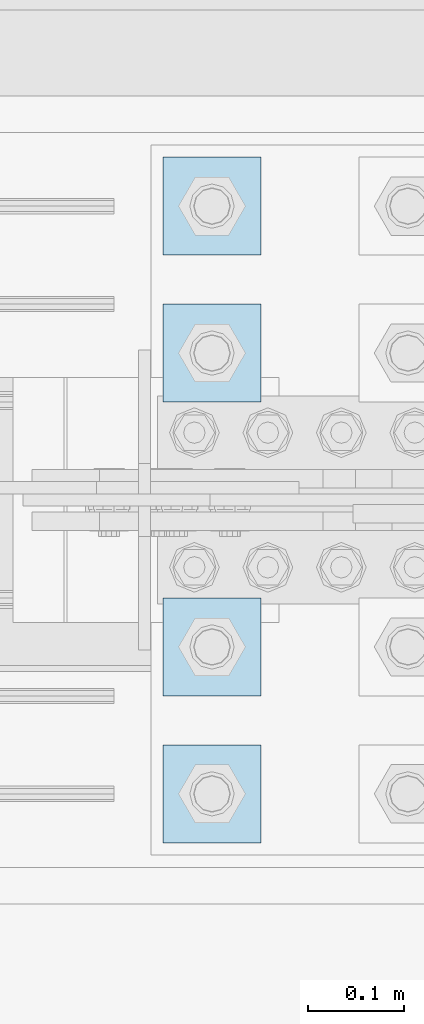
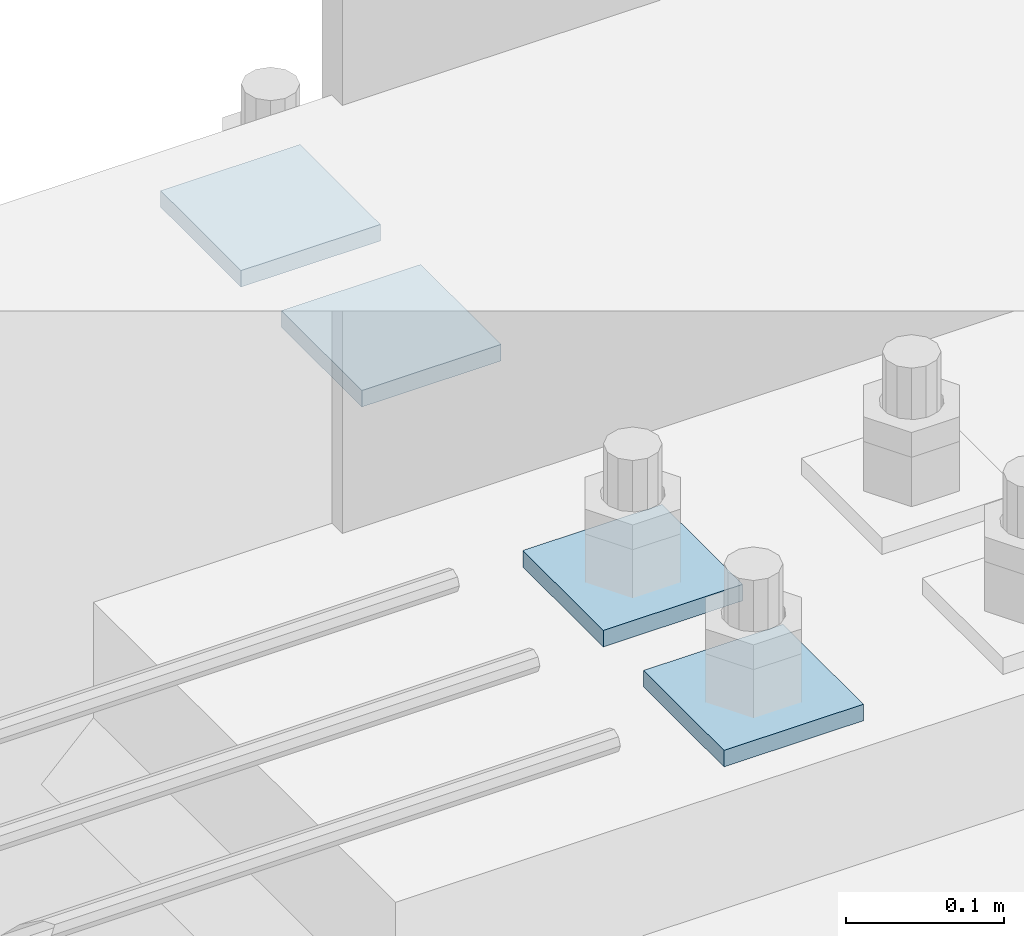
# One storey, part 3474 of 3843: 4 plates, 1 element without a shape of its own.
"""IFC2X3 building model written with IfcOpenShell, lengths in millimetres."""

from ifc_helpers import new_model, si_unit, frame, origin_with_axes, place, context, subcontext, project, spatial, faceted_brep, material, type_object, element, aggregate, save


model = new_model("IFC2X3")

# Units and contexts
model_context = context("Model", 3, precision=1e-05, world=origin_with_axes())
body_context = subcontext(model_context, "Body", "Model", "MODEL_VIEW")
ifc_project = project(units=[si_unit("LENGTHUNIT", "METRE", prefix="MILLI"), si_unit("AREAUNIT", "SQUARE_METRE"), si_unit("VOLUMEUNIT", "CUBIC_METRE"), si_unit("MASSUNIT", "GRAM", prefix="KILO"), si_unit("TIMEUNIT", "SECOND"), si_unit("PLANEANGLEUNIT", "RADIAN"), si_unit("SOLIDANGLEUNIT", "STERADIAN"), si_unit("THERMODYNAMICTEMPERATUREUNIT", "DEGREE_CELSIUS"), si_unit("LUMINOUSINTENSITYUNIT", "LUMEN")], contexts=[model_context])

# Site, building, storey
site_placement = place(None, origin_with_axes())
site = spatial("IfcSite", under=ifc_project, at=site_placement, CompositionType="ELEMENT")
building_placement = place(site_placement, origin_with_axes())
building = spatial("IfcBuilding", under=site, at=building_placement, Name="Undefined", CompositionType="ELEMENT")
storey_placement = place(building_placement, origin_with_axes())
storey = spatial("IfcBuildingStorey", under=building, at=storey_placement, Name="Undefined", CompositionType="ELEMENT", Elevation=0.0)

# Assembly, plates
assembly_placement = place(storey_placement, origin_with_axes())
assembly = element("IfcElementAssembly", 1, at=assembly_placement, inside=storey, Name="TEMPLATE", AssemblyPlace="NOTDEFINED", PredefinedType="RIGID_FRAME")
ifc_material = material(Name="STEEL/A572-50")
plate_type = type_object("IfcPlateType", PredefinedType="NOTDEFINED")
plate_1_placement = place(assembly_placement, frame((55473.6, 91960.7, 30156.15), z_axis=(-1.0, 0.0, 0.0), x_axis=(0.0, -1.0, 0.0)))
plate_1 = element("IfcPlate", 2, at=plate_1_placement, type_object=plate_type, material=ifc_material, Name="Washer Plate", context=body_context, shape_type="Brep", body=[
    faceted_brep([(0.0, -6.3499999046162, 0.0), (-1.67347025126219e-10, -6.35000000000582, 101.600000000151), (-1.67347025126219e-10, 6.35000000000582, 101.600000000151), (7.27595761418343e-12, 6.3499999046162, 0.0), (101.599998474121, -6.34999999999854, 101.599998474121), (101.599998474121, 6.34999999999854, 101.599998474121), (101.6, -6.34999999999854, 0.0), (101.6, 6.34999999999854, 0.0)], [[[0, 1, 2, 3]], [[1, 4, 5, 2]], [[4, 6, 7, 5]], [[6, 0, 3, 7]], [[5, 7, 3, 2]], [[6, 4, 1, 0]]]),
])
plate_2_placement = place(assembly_placement, frame((55473.6, 92113.1, 30156.15), z_axis=(-1.0, 0.0, 0.0), x_axis=(0.0, -1.0, 0.0)))
plate_2 = element("IfcPlate", 3, at=plate_2_placement, type_object=plate_type, material=ifc_material, Name="Washer Plate", context=body_context, shape_type="Brep", body=[
    faceted_brep([(0.0, -6.3499999046162, 0.0), (-1.67347025126219e-10, -6.35000000000582, 101.600000000151), (-1.67347025126219e-10, 6.35000000000582, 101.600000000151), (7.27595761418343e-12, 6.3499999046162, 0.0), (101.599998474121, -6.34999999999854, 101.599998474121), (101.599998474121, 6.34999999999854, 101.599998474121), (101.6, -6.34999999999854, 0.0), (101.6, 6.34999999999854, 0.0)], [[[0, 1, 2, 3]], [[1, 4, 5, 2]], [[4, 6, 7, 5]], [[6, 0, 3, 7]], [[5, 7, 3, 2]], [[6, 4, 1, 0]]]),
])
plate_3_placement = place(assembly_placement, frame((55473.6, 92417.9, 30156.15), z_axis=(-1.0, 0.0, 0.0), x_axis=(0.0, -1.0, 0.0)))
plate_3 = element("IfcPlate", 4, at=plate_3_placement, type_object=plate_type, material=ifc_material, Name="Washer Plate", context=body_context, shape_type="Brep", body=[
    faceted_brep([(0.0, -6.3499999046162, 0.0), (-1.67347025126219e-10, -6.35000000000582, 101.600000000151), (-1.67347025126219e-10, 6.35000000000582, 101.600000000151), (7.27595761418343e-12, 6.3499999046162, 0.0), (101.599998474121, -6.34999999999854, 101.599998474121), (101.599998474121, 6.34999999999854, 101.599998474121), (101.6, -6.34999999999854, 0.0), (101.6, 6.34999999999854, 0.0)], [[[0, 1, 2, 3]], [[1, 4, 5, 2]], [[4, 6, 7, 5]], [[6, 0, 3, 7]], [[5, 7, 3, 2]], [[6, 4, 1, 0]]]),
])
plate_4_placement = place(assembly_placement, frame((55473.6, 92570.3, 30156.15), z_axis=(-1.0, 0.0, 0.0), x_axis=(0.0, -1.0, 0.0)))
plate_4 = element("IfcPlate", 5, at=plate_4_placement, type_object=plate_type, material=ifc_material, Name="Washer Plate", context=body_context, shape_type="Brep", body=[
    faceted_brep([(0.0, -6.3499999046162, 0.0), (-1.67347025126219e-10, -6.35000000000582, 101.600000000151), (-1.67347025126219e-10, 6.35000000000582, 101.600000000151), (7.27595761418343e-12, 6.3499999046162, 0.0), (101.599998474121, -6.34999999999854, 101.599998474121), (101.599998474121, 6.34999999999854, 101.599998474121), (101.6, -6.34999999999854, 0.0), (101.6, 6.34999999999854, 0.0)], [[[0, 1, 2, 3]], [[1, 4, 5, 2]], [[4, 6, 7, 5]], [[6, 0, 3, 7]], [[5, 7, 3, 2]], [[6, 4, 1, 0]]]),
])
aggregate(assembly, [plate_1, plate_2, plate_3, plate_4])

save(model, "model.ifc")
